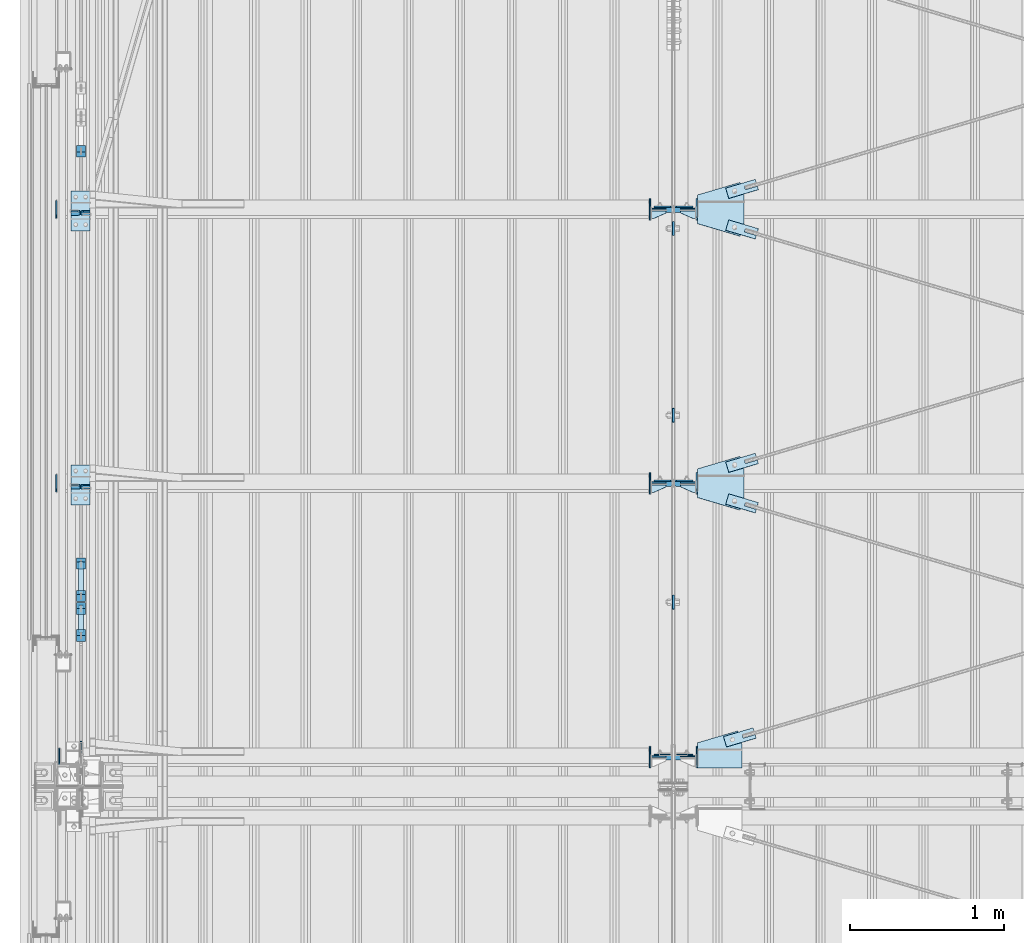
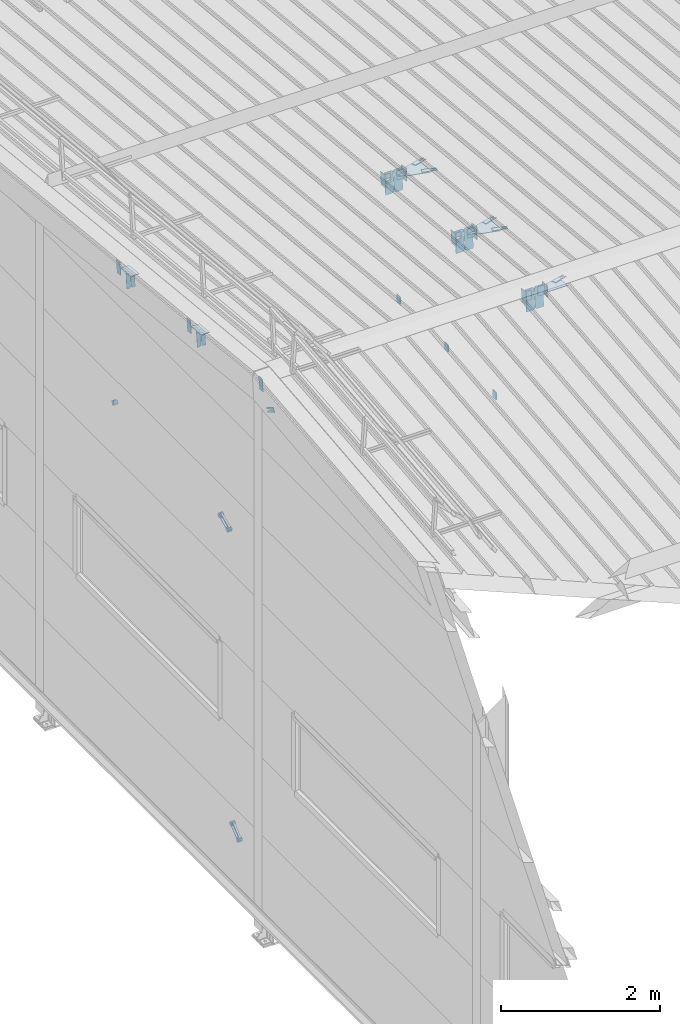
# One storey, part 118 of 709: 52 plates, 5 openings, 20 elements without a shape of their own.
"""IFC4 building model written with IfcOpenShell, lengths in millimetres."""

from ifc_helpers import new_model, si_unit, direction, frame, origin_with_axes, place, context, subcontext, project, spatial, line, indexed_curve, outline, extrude, material, element, aggregate, save


model = new_model("IFC4")

# Units and contexts
model_context = context("Model", 3, precision=0.2, world=origin_with_axes(), true_north=direction((0.0, 1.0)))
body_context = subcontext(model_context, "Body", "Model", "MODEL_VIEW")
ifc_project = project(units=[si_unit("LENGTHUNIT", "METRE", prefix="MILLI"), si_unit("AREAUNIT", "SQUARE_METRE"), si_unit("VOLUMEUNIT", "CUBIC_METRE"), si_unit("MASSUNIT", "GRAM", prefix="KILO"), si_unit("TIMEUNIT", "SECOND"), si_unit("PLANEANGLEUNIT", "RADIAN"), si_unit("SOLIDANGLEUNIT", "STERADIAN"), si_unit("THERMODYNAMICTEMPERATUREUNIT", "DEGREE_CELSIUS"), si_unit("LUMINOUSINTENSITYUNIT", "LUMEN")], contexts=[model_context])

# Site, building, storey
site_placement = place(None, origin_with_axes())
site = spatial("IfcSite", under=ifc_project, at=site_placement, CompositionType="ELEMENT")
building_placement = place(site_placement, origin_with_axes())
building = spatial("IfcBuilding", under=site, at=building_placement, Name="Undefined", CompositionType="ELEMENT")
storey_placement = place(building_placement, origin_with_axes())
storey = spatial("IfcBuildingStorey", under=building, at=storey_placement, Name="Undefined", CompositionType="ELEMENT", Elevation=0.0)

# Assembly, plates
assembly_1_placement = place(storey_placement, frame((4000.0, 21654.0, 7089.70002), z_axis=(-1.0, 0.0, 0.0), x_axis=(0.0, -0.9950371902, 0.099503719)))
assembly_1 = element("IfcElementAssembly", 1, at=assembly_1_placement, inside=storey)
ifc_material_1 = material(Name="C355-6", Category="STEEL")
plate_1_placement = place(assembly_1_placement, frame((10515.436, 163.0, 127.0), z_axis=(-1.0, 0.0, 0.0), x_axis=(0.0, 0.0, -1.0)))
plate_1 = element("IfcPlate", 2, at=plate_1_placement, material=ifc_material_1, ObjectType="585", context=body_context, shape_type="SolidModel", body=[
    extrude(outline(indexed_curve([(0.0, 0.0), (108.0, 0.0), (123.0, 15.0), (123.0, 311.0), (108.0, 326.0), (0.0, 326.0)], segments=[line(1, 2, 3, 4, 5, 6, 1)])), frame((0.0, 0.0, 4.0), z_axis=(0.0, 0.0, 1.0), x_axis=(1.0, 0.0, 0.0)), (0.0, 0.0, -1.0), 8.0),
])
plate_2_placement = place(assembly_1_placement, frame((10515.43997, 163.0, -127.0), z_axis=(1.0, 0.0, 0.0), x_axis=(0.0, 0.0, 1.0)))
plate_2 = element("IfcPlate", 3, at=plate_2_placement, material=ifc_material_1, ObjectType="589", context=body_context, shape_type="SolidModel", body=[
    extrude(outline(indexed_curve([(0.0, 0.0), (108.0, 0.0), (123.0, 15.0), (123.0, 311.0), (108.0, 326.0), (0.0, 326.0)], segments=[line(1, 2, 3, 4, 5, 6, 1)])), frame((0.0, 0.0, 4.0), z_axis=(0.0, 0.0, 1.0), x_axis=(1.0, 0.0, 0.0)), (0.0, 0.0, -1.0), 8.0),
])
plate_3_placement = place(assembly_1_placement, frame((8733.29131, 163.0, 127.0), z_axis=(-1.0, 0.0, 0.0), x_axis=(0.0, 0.0, -1.0)))
plate_3 = element("IfcPlate", 4, at=plate_3_placement, material=ifc_material_1, ObjectType="585", context=body_context, shape_type="SolidModel", body=[
    extrude(outline(indexed_curve([(0.0, 0.0), (108.0, 0.0), (123.0, 15.0), (123.0, 311.0), (108.0, 326.0), (0.0, 326.0)], segments=[line(1, 2, 3, 4, 5, 6, 1)])), frame((0.0, 0.0, 4.0), z_axis=(0.0, 0.0, 1.0), x_axis=(1.0, 0.0, 0.0)), (0.0, 0.0, -1.0), 8.0),
])
plate_4_placement = place(assembly_1_placement, frame((8733.29528, 163.0, -127.0), z_axis=(1.0, 0.0, 0.0), x_axis=(0.0, 0.0, 1.0)))
plate_4 = element("IfcPlate", 5, at=plate_4_placement, material=ifc_material_1, ObjectType="585", context=body_context, shape_type="SolidModel", body=[
    extrude(outline(indexed_curve([(0.0, 0.0), (108.0, 0.0), (123.0, 15.0), (123.0, 311.0), (108.0, 326.0), (0.0, 326.0)], segments=[line(1, 2, 3, 4, 5, 6, 1)])), frame((0.0, 0.0, 4.0), z_axis=(0.0, 0.0, 1.0), x_axis=(1.0, 0.0, 0.0)), (0.0, 0.0, -1.0), 8.0),
])
plate_5_placement = place(assembly_1_placement, frame((6951.14662, 163.0, 127.0), z_axis=(-1.0, 0.0, 0.0), x_axis=(0.0, 0.0, -1.0)))
plate_5 = element("IfcPlate", 6, at=plate_5_placement, material=ifc_material_1, ObjectType="585", context=body_context, shape_type="SolidModel", body=[
    extrude(outline(indexed_curve([(0.0, 0.0), (108.0, 0.0), (123.0, 15.0), (123.0, 311.0), (108.0, 326.0), (0.0, 326.0)], segments=[line(1, 2, 3, 4, 5, 6, 1)])), frame((0.0, 0.0, 4.0), z_axis=(0.0, 0.0, 1.0), x_axis=(1.0, 0.0, 0.0)), (0.0, 0.0, -1.0), 8.0),
])
plate_6_placement = place(assembly_1_placement, frame((6951.15059, 163.0, -127.0), z_axis=(1.0, 0.0, 0.0), x_axis=(0.0, 0.0, 1.0)))
plate_6 = element("IfcPlate", 7, at=plate_6_placement, material=ifc_material_1, ObjectType="585", context=body_context, shape_type="SolidModel", body=[
    extrude(outline(indexed_curve([(0.0, 0.0), (108.0, 0.0), (123.0, 15.0), (123.0, 311.0), (108.0, 326.0), (0.0, 326.0)], segments=[line(1, 2, 3, 4, 5, 6, 1)])), frame((0.0, 0.0, 4.0), z_axis=(0.0, 0.0, 1.0), x_axis=(1.0, 0.0, 0.0)), (0.0, 0.0, -1.0), 8.0),
])
aggregate(assembly_1, [plate_1, plate_2, plate_3, plate_4, plate_5, plate_6])

assembly_2_placement = place(storey_placement, frame((162.5, 16500.0, 7445.307), z_axis=(-1.0, 0.0, 0.0), x_axis=(0.0, -0.9950371902, 0.099503719)))
assembly_2 = element("IfcElementAssembly", 8, at=assembly_2_placement, inside=storey)
plate_7_placement = place(assembly_2_placement, frame((3577.48542, 115.0, 62.0), z_axis=(-1.0, 0.0, 0.0), x_axis=(0.0, 0.0, -1.0)))
plate_7 = element("IfcPlate", 9, at=plate_7_placement, material=ifc_material_1, ObjectType="594", context=body_context, shape_type="SolidModel", body=[
    extrude(outline(indexed_curve([(0.0, 0.0), (43.5, 0.0), (58.5, 15.0), (58.5, 215.0), (43.5, 230.0), (0.0, 230.0)], segments=[line(1, 2, 3, 4, 5, 6, 1)])), frame((0.0, 0.0, 4.0), z_axis=(0.0, 0.0, 1.0), x_axis=(1.0, 0.0, 0.0)), (0.0, 0.0, -1.0), 8.0),
])
plate_8_placement = place(assembly_2_placement, frame((3577.48542, -115.0, -62.0), z_axis=(-1.0, 0.0, 0.0), x_axis=(0.0, 0.0, 1.0)))
plate_8 = element("IfcPlate", 10, at=plate_8_placement, material=ifc_material_1, ObjectType="594", context=body_context, shape_type="SolidModel", body=[
    extrude(outline(indexed_curve([(0.0, 0.0), (43.5, 0.0), (58.5, 15.0), (58.5, 215.0), (43.5, 230.0), (0.0, 230.0)], segments=[line(1, 2, 3, 4, 5, 6, 1)])), frame((0.0, 0.0, 4.0), z_axis=(0.0, 0.0, 1.0), x_axis=(1.0, 0.0, 0.0)), (0.0, 0.0, -1.0), 8.0),
])
plate_9_placement = place(assembly_2_placement, frame((1795.34072, -115.0, -62.0), z_axis=(-1.0, 0.0, 0.0), x_axis=(0.0, 0.0, 1.0)))
plate_9 = element("IfcPlate", 11, at=plate_9_placement, material=ifc_material_1, ObjectType="594", context=body_context, shape_type="SolidModel", body=[
    extrude(outline(indexed_curve([(0.0, 0.0), (43.5, 0.0), (58.5, 15.0), (58.5, 215.0), (43.5, 230.0), (0.0, 230.0)], segments=[line(1, 2, 3, 4, 5, 6, 1)])), frame((0.0, 0.0, 4.0), z_axis=(0.0, 0.0, 1.0), x_axis=(1.0, 0.0, 0.0)), (0.0, 0.0, -1.0), 8.0),
])
plate_10_placement = place(assembly_2_placement, frame((1795.34072, 115.0, 62.0), z_axis=(-1.0, 0.0, 0.0), x_axis=(0.0, 0.0, -1.0)))
plate_10 = element("IfcPlate", 12, at=plate_10_placement, material=ifc_material_1, ObjectType="594", context=body_context, shape_type="SolidModel", body=[
    extrude(outline(indexed_curve([(0.0, 0.0), (43.5, 0.0), (58.5, 15.0), (58.5, 215.0), (43.5, 230.0), (0.0, 230.0)], segments=[line(1, 2, 3, 4, 5, 6, 1)])), frame((0.0, 0.0, 4.0), z_axis=(0.0, 0.0, 1.0), x_axis=(1.0, 0.0, 0.0)), (0.0, 0.0, -1.0), 8.0),
])
aggregate(assembly_2, [plate_7, plate_8, plate_9, plate_10])

# Assembly, plate
assembly_3_placement = place(storey_placement, frame((4000.0, 12149.25, 6100.00002), z_axis=(-1.0, 0.0, 0.0), x_axis=(0.0, 1.0, 0.0)))
assembly_3 = element("IfcElementAssembly", 13, at=assembly_3_placement, inside=storey)
plate_11_placement = place(assembly_3_placement, origin_with_axes())
plate_11 = element("IfcPlate", 14, at=plate_11_placement, material=ifc_material_1, ObjectType="491", context=body_context, shape_type="SolidModel", body=[
    extrude(outline(indexed_curve([(0.0, 0.0), (90.0, 0.0), (90.0, 110.0), (0.0, 110.0)], segments=[line(1, 2, 3, 4, 1)])), frame((0.0, 0.0, 6.0), z_axis=(0.0, 0.0, 1.0), x_axis=(1.0, 0.0, 0.0)), (0.0, 0.0, -1.0), 12.0),
])
aggregate(assembly_3, [plate_11])

assembly_4_placement = place(storey_placement, frame((4000.0, 13358.5, 6100.00002), z_axis=(-1.0, 0.0, 0.0), x_axis=(0.0, 1.0, 0.0)))
assembly_4 = element("IfcElementAssembly", 15, at=assembly_4_placement, inside=storey)
plate_12_placement = place(assembly_4_placement, origin_with_axes())
plate_12 = element("IfcPlate", 16, at=plate_12_placement, material=ifc_material_1, ObjectType="491", context=body_context, shape_type="SolidModel", body=[
    extrude(outline(indexed_curve([(0.0, 0.0), (90.0, 0.0), (90.0, 110.0), (0.0, 110.0)], segments=[line(1, 2, 3, 4, 1)])), frame((0.0, 0.0, 6.0), z_axis=(0.0, 0.0, 1.0), x_axis=(1.0, 0.0, 0.0)), (0.0, 0.0, -1.0), 12.0),
])
aggregate(assembly_4, [plate_12])

assembly_5_placement = place(storey_placement, frame((4000.0, 14567.75, 6100.00002), z_axis=(-1.0, 0.0, 0.0), x_axis=(0.0, 1.0, 0.0)))
assembly_5 = element("IfcElementAssembly", 17, at=assembly_5_placement, inside=storey)
plate_13_placement = place(assembly_5_placement, origin_with_axes())
plate_13 = element("IfcPlate", 18, at=plate_13_placement, material=ifc_material_1, ObjectType="491", context=body_context, shape_type="SolidModel", body=[
    extrude(outline(indexed_curve([(0.0, 0.0), (90.0, 0.0), (90.0, 110.0), (0.0, 110.0)], segments=[line(1, 2, 3, 4, 1)])), frame((0.0, 0.0, 6.0), z_axis=(0.0, 0.0, 1.0), x_axis=(1.0, 0.0, 0.0)), (0.0, 0.0, -1.0), 12.0),
])
aggregate(assembly_5, [plate_13])

# Assembly, plates
assembly_6_placement = place(storey_placement, frame((135.0, 11957.52993, 702.47387), z_axis=(0.0, 0.7603239329, 0.649544084), x_axis=(1.0, 0.0, 0.0)))
assembly_6 = element("IfcElementAssembly", 19, at=assembly_6_placement, inside=storey)
ifc_material_2 = material(Name="Steel_Undefined", Category="STEEL")
plate_14_placement = place(assembly_6_placement, origin_with_axes())
plate_14 = element("IfcPlate", 20, at=plate_14_placement, material=ifc_material_2, ObjectType="482", context=body_context, shape_type="SolidModel", body=[
    extrude(outline(indexed_curve([(0.0, 0.0), (60.0, 0.0), (60.0, 60.0), (0.0, 60.0)], segments=[line(1, 2, 3, 4, 1)])), frame((0.0, 0.0, 25.0), z_axis=(0.0, 0.0, 1.0), x_axis=(1.0, 0.0, 0.0)), (0.0, 0.0, -1.0), 50.0),
])
plate_15_placement = place(assembly_6_placement, frame((15.0, 66.0, 230.0), z_axis=(0.0, 1.0, 0.0), x_axis=(1.0, 0.0, 0.0)))
plate_15 = element("IfcPlate", 21, at=plate_15_placement, material=ifc_material_2, ObjectType="484", context=body_context, shape_type="SolidModel", body=[
    extrude(outline(indexed_curve([(0.0, 0.0), (30.0, 0.0), (30.0, 230.0), (0.0, 230.0)], segments=[line(1, 2, 3, 4, 1)])), frame((0.0, 0.0, 6.0), z_axis=(0.0, 0.0, 1.0), x_axis=(1.0, 0.0, 0.0)), (0.0, 0.0, -1.0), 12.0),
])
plate_16_placement = place(assembly_6_placement, frame((15.0, -6.0, 230.0), z_axis=(0.0, 1.0, 0.0), x_axis=(1.0, 0.0, 0.0)))
plate_16 = element("IfcPlate", 22, at=plate_16_placement, material=ifc_material_2, ObjectType="484", context=body_context, shape_type="SolidModel", body=[
    extrude(outline(indexed_curve([(0.0, 0.0), (30.0, 0.0), (30.0, 230.0), (0.0, 230.0)], segments=[line(1, 2, 3, 4, 1)])), frame((0.0, 0.0, 6.0), z_axis=(0.0, 0.0, 1.0), x_axis=(1.0, 0.0, 0.0)), (0.0, 0.0, -1.0), 12.0),
])
plate_17_placement = place(assembly_6_placement, frame((0.0, 0.0, 230.0), z_axis=(0.0, 0.0, 1.0), x_axis=(1.0, 0.0, 0.0)))
plate_17 = element("IfcPlate", 23, at=plate_17_placement, material=ifc_material_2, ObjectType="483", context=body_context, shape_type="SolidModel", body=[
    extrude(outline(indexed_curve([(0.0, 0.0), (60.0, 0.0), (60.0, 60.0), (0.0, 60.0)], segments=[line(1, 2, 3, 4, 1)])), frame((0.0, 0.0, 25.0), z_axis=(0.0, 0.0, 1.0), x_axis=(1.0, 0.0, 0.0)), (0.0, 0.0, -1.0), 50.0),
])
aggregate(assembly_6, [plate_14, plate_15, plate_16, plate_17])

# Assembly, plate
assembly_7_placement = place(storey_placement, frame((165.0, 15212.89749, 5439.71077), z_axis=(-1.0, 0.0, 0.0), x_axis=(0.0, -0.866144648, 0.499793406)))
assembly_7 = element("IfcElementAssembly", 24, at=assembly_7_placement, inside=storey)
plate_18_placement = place(assembly_7_placement, frame((4543.87607, -11.0, 0.0), z_axis=(0.0, 0.0, -1.0), x_axis=(1.0, 0.0, 0.0)))
plate_18 = element("IfcPlate", 25, at=plate_18_placement, material=ifc_material_1, ObjectType="490", context=body_context, shape_type="SolidModel", body=[
    extrude(outline(indexed_curve([(0.0, 0.0), (80.0, 0.0), (80.0, -22.0), (0.0, -22.0), (0.0, -46.0), (200.0, -46.0), (200.0, 24.0), (0.0, 24.0)], segments=[line(1, 2, 3, 4, 5, 6, 7, 8, 1)])), frame((0.0, 0.0, 4.0), z_axis=(0.0, 0.0, 1.0), x_axis=(1.0, 0.0, 0.0)), (0.0, 0.0, -1.0), 8.0),
])
aggregate(assembly_7, [plate_18])

assembly_8_placement = place(storey_placement, frame((135.0, 15128.28466, 5523.17135), z_axis=(0.0, 0.866144648, -0.499793406), x_axis=(1.0, 0.0, 0.0)))
assembly_8 = element("IfcElementAssembly", 26, at=assembly_8_placement, inside=storey)
plate_19_placement = place(assembly_8_placement, origin_with_axes())
plate_19 = element("IfcPlate", 27, at=plate_19_placement, material=ifc_material_2, ObjectType="482", context=body_context, shape_type="SolidModel", body=[
    extrude(outline(indexed_curve([(0.0, 0.0), (60.0, 0.0), (60.0, 60.0), (0.0, 60.0)], segments=[line(1, 2, 3, 4, 1)])), frame((0.0, 0.0, 25.0), z_axis=(0.0, 0.0, 1.0), x_axis=(1.0, 0.0, 0.0)), (0.0, 0.0, -1.0), 50.0),
])
aggregate(assembly_8, [plate_19])

# Assembly, plates
assembly_9_placement = place(storey_placement, frame((135.0, 12222.02873, 5319.05338), z_axis=(0.0, 0.9030466941, 0.429542394), x_axis=(1.0, 0.0, 0.0)))
assembly_9 = element("IfcElementAssembly", 28, at=assembly_9_placement, inside=storey)
plate_20_placement = place(assembly_9_placement, frame((15.0, 66.0, 230.0), z_axis=(0.0, 1.0, 0.0), x_axis=(1.0, 0.0, 0.0)))
plate_20 = element("IfcPlate", 29, at=plate_20_placement, material=ifc_material_2, ObjectType="484", context=body_context, shape_type="SolidModel", body=[
    extrude(outline(indexed_curve([(0.0, 0.0), (30.0, 0.0), (30.0, 230.0), (0.0, 230.0)], segments=[line(1, 2, 3, 4, 1)])), frame((0.0, 0.0, 6.0), z_axis=(0.0, 0.0, 1.0), x_axis=(1.0, 0.0, 0.0)), (0.0, 0.0, -1.0), 12.0),
])
plate_21_placement = place(assembly_9_placement, frame((15.0, -6.0, 230.0), z_axis=(0.0, 1.0, 0.0), x_axis=(1.0, 0.0, 0.0)))
plate_21 = element("IfcPlate", 30, at=plate_21_placement, material=ifc_material_2, ObjectType="484", context=body_context, shape_type="SolidModel", body=[
    extrude(outline(indexed_curve([(0.0, 0.0), (30.0, 0.0), (30.0, 230.0), (0.0, 230.0)], segments=[line(1, 2, 3, 4, 1)])), frame((0.0, 0.0, 6.0), z_axis=(0.0, 0.0, 1.0), x_axis=(1.0, 0.0, 0.0)), (0.0, 0.0, -1.0), 12.0),
])
plate_22_placement = place(assembly_9_placement, frame((0.0, 0.0, 230.0), z_axis=(0.0, 0.0, 1.0), x_axis=(1.0, 0.0, 0.0)))
plate_22 = element("IfcPlate", 31, at=plate_22_placement, material=ifc_material_2, ObjectType="483", context=body_context, shape_type="SolidModel", body=[
    extrude(outline(indexed_curve([(0.0, 0.0), (60.0, 0.0), (60.0, 60.0), (0.0, 60.0)], segments=[line(1, 2, 3, 4, 1)])), frame((0.0, 0.0, 25.0), z_axis=(0.0, 0.0, 1.0), x_axis=(1.0, 0.0, 0.0)), (0.0, 0.0, -1.0), 50.0),
])
plate_23_placement = place(assembly_9_placement, origin_with_axes())
plate_23 = element("IfcPlate", 32, at=plate_23_placement, material=ifc_material_2, ObjectType="482", context=body_context, shape_type="SolidModel", body=[
    extrude(outline(indexed_curve([(0.0, 0.0), (60.0, 0.0), (60.0, 60.0), (0.0, 60.0)], segments=[line(1, 2, 3, 4, 1)])), frame((0.0, 0.0, 25.0), z_axis=(0.0, 0.0, 1.0), x_axis=(1.0, 0.0, 0.0)), (0.0, 0.0, -1.0), 50.0),
])
aggregate(assembly_9, [plate_20, plate_21, plate_22, plate_23])

# Assembly, plate, voiding feature
assembly_10_placement = place(storey_placement, frame((4000.0, 11190.84566, 8217.41945), z_axis=(0.2847296511, -0.9538504697, 0.095385047), x_axis=(0.9586078582, 0.2833165921, -0.028331659)))
assembly_10 = element("IfcElementAssembly", 33, at=assembly_10_placement, inside=storey)
plate_24_placement = place(assembly_10_placement, frame((348.68279, 0.0, -35.0), z_axis=(0.0, 1.0, 0.0), x_axis=(0.0, 0.0, 1.0)))
plate_24 = element("IfcPlate", 34, at=plate_24_placement, material=ifc_material_1, ObjectType="574", context=body_context, shape_type="SolidModel", body=[
    extrude(outline(indexed_curve([(0.0, 0.0), (70.0, 0.0), (70.0, 200.0), (0.0, 200.0)], segments=[line(1, 2, 3, 4, 1)])), frame((0.0, 0.0, 4.0), z_axis=(0.0, 0.0, 1.0), x_axis=(1.0, 0.0, 0.0)), (0.0, 0.0, -1.0), 8.0),
])
voiding_feature_1_placement = place(plate_24_placement, frame((24.0, 120.0, 0.0), z_axis=(0.0, 0.0, 1.0), x_axis=(1.0, 0.0, 0.0)))
element("IfcVoidingFeature", 35, at=voiding_feature_1_placement, cuts=plate_24, Name="PLATE", PredefinedType="HOLE", context=body_context, shape_type="SolidModel", body=[
    extrude(outline(indexed_curve([(0.0, 0.0), (22.0, 0.0), (22.0, 85.0), (0.0, 85.0)], segments=[line(1, 2, 3, 4, 1)])), frame((0.0, 0.0, 6.5), z_axis=(0.0, 0.0, 1.0), x_axis=(1.0, 0.0, 0.0)), (0.0, 0.0, -1.0), 13.0),
])
aggregate(assembly_10, [plate_24])

assembly_11_placement = place(storey_placement, frame((4000.0, 12964.14591, 8040.08943), z_axis=(-0.2847296511, -0.9538504697, 0.095385047), x_axis=(0.9586078582, -0.2833165921, 0.028331659)))
assembly_11 = element("IfcElementAssembly", 36, at=assembly_11_placement, inside=storey)
plate_25_placement = place(assembly_11_placement, frame((363.68279, 0.0, -35.0), z_axis=(0.0, 1.0, 0.0), x_axis=(0.0, 0.0, 1.0)))
plate_25 = element("IfcPlate", 37, at=plate_25_placement, material=ifc_material_1, ObjectType="574", context=body_context, shape_type="SolidModel", body=[
    extrude(outline(indexed_curve([(0.0, 0.0), (70.0, 0.0), (70.0, 200.0), (0.0, 200.0)], segments=[line(1, 2, 3, 4, 1)])), frame((0.0, 0.0, 4.0), z_axis=(0.0, 0.0, 1.0), x_axis=(1.0, 0.0, 0.0)), (0.0, 0.0, -1.0), 8.0),
])
voiding_feature_2_placement = place(plate_25_placement, frame((24.0, 120.0, 0.0), z_axis=(0.0, 0.0, 1.0), x_axis=(1.0, 0.0, 0.0)))
element("IfcVoidingFeature", 38, at=voiding_feature_2_placement, cuts=plate_25, Name="PLATE", PredefinedType="HOLE", context=body_context, shape_type="SolidModel", body=[
    extrude(outline(indexed_curve([(0.0, 0.0), (22.0, 0.0), (22.0, 85.0), (0.0, 85.0)], segments=[line(1, 2, 3, 4, 1)])), frame((0.0, 0.0, 6.5), z_axis=(0.0, 0.0, 1.0), x_axis=(1.0, 0.0, 0.0)), (0.0, 0.0, -1.0), 13.0),
])
aggregate(assembly_11, [plate_25])

assembly_12_placement = place(storey_placement, frame((4000.0, 12964.14591, 8040.08943), z_axis=(0.2847296511, -0.9538504697, 0.095385047), x_axis=(0.9586078582, 0.2833165921, -0.028331659)))
assembly_12 = element("IfcElementAssembly", 39, at=assembly_12_placement, inside=storey)
plate_26_placement = place(assembly_12_placement, frame((363.68279, 0.0, -35.0), z_axis=(0.0, 1.0, 0.0), x_axis=(0.0, 0.0, 1.0)))
plate_26 = element("IfcPlate", 40, at=plate_26_placement, material=ifc_material_1, ObjectType="574", context=body_context, shape_type="SolidModel", body=[
    extrude(outline(indexed_curve([(0.0, 0.0), (70.0, 0.0), (70.0, 200.0), (0.0, 200.0)], segments=[line(1, 2, 3, 4, 1)])), frame((0.0, 0.0, 4.0), z_axis=(0.0, 0.0, 1.0), x_axis=(1.0, 0.0, 0.0)), (0.0, 0.0, -1.0), 8.0),
])
voiding_feature_3_placement = place(plate_26_placement, frame((24.0, 120.0, 0.0), z_axis=(0.0, 0.0, 1.0), x_axis=(1.0, 0.0, 0.0)))
element("IfcVoidingFeature", 41, at=voiding_feature_3_placement, cuts=plate_26, Name="PLATE", PredefinedType="HOLE", context=body_context, shape_type="SolidModel", body=[
    extrude(outline(indexed_curve([(0.0, 0.0), (22.0, 0.0), (22.0, 85.0), (0.0, 85.0)], segments=[line(1, 2, 3, 4, 1)])), frame((0.0, 0.0, 6.5), z_axis=(0.0, 0.0, 1.0), x_axis=(1.0, 0.0, 0.0)), (0.0, 0.0, -1.0), 13.0),
])
aggregate(assembly_12, [plate_26])

assembly_13_placement = place(storey_placement, frame((4000.0, 14737.44615, 7862.7594), z_axis=(-0.2847296511, -0.9538504697, 0.095385047), x_axis=(0.9586078582, -0.2833165921, 0.028331659)))
assembly_13 = element("IfcElementAssembly", 42, at=assembly_13_placement, inside=storey)
plate_27_placement = place(assembly_13_placement, frame((363.68279, 0.0, -35.0), z_axis=(0.0, 1.0, 0.0), x_axis=(0.0, 0.0, 1.0)))
plate_27 = element("IfcPlate", 43, at=plate_27_placement, material=ifc_material_1, ObjectType="574", context=body_context, shape_type="SolidModel", body=[
    extrude(outline(indexed_curve([(0.0, 0.0), (70.0, 0.0), (70.0, 200.0), (0.0, 200.0)], segments=[line(1, 2, 3, 4, 1)])), frame((0.0, 0.0, 4.0), z_axis=(0.0, 0.0, 1.0), x_axis=(1.0, 0.0, 0.0)), (0.0, 0.0, -1.0), 8.0),
])
voiding_feature_4_placement = place(plate_27_placement, frame((24.0, 120.0, 0.0), z_axis=(0.0, 0.0, 1.0), x_axis=(1.0, 0.0, 0.0)))
element("IfcVoidingFeature", 44, at=voiding_feature_4_placement, cuts=plate_27, Name="PLATE", PredefinedType="HOLE", context=body_context, shape_type="SolidModel", body=[
    extrude(outline(indexed_curve([(0.0, 0.0), (22.0, 0.0), (22.0, 85.0), (0.0, 85.0)], segments=[line(1, 2, 3, 4, 1)])), frame((0.0, 0.0, 6.5), z_axis=(0.0, 0.0, 1.0), x_axis=(1.0, 0.0, 0.0)), (0.0, 0.0, -1.0), 13.0),
])
aggregate(assembly_13, [plate_27])

assembly_14_placement = place(storey_placement, frame((4000.0, 14737.44615, 7862.7594), z_axis=(0.2847296511, -0.9538504697, 0.095385047), x_axis=(0.9586078582, 0.2833165921, -0.028331659)))
assembly_14 = element("IfcElementAssembly", 45, at=assembly_14_placement, inside=storey)
plate_28_placement = place(assembly_14_placement, frame((363.68279, 0.0, -35.0), z_axis=(0.0, 1.0, 0.0), x_axis=(0.0, 0.0, 1.0)))
plate_28 = element("IfcPlate", 46, at=plate_28_placement, material=ifc_material_1, ObjectType="574", context=body_context, shape_type="SolidModel", body=[
    extrude(outline(indexed_curve([(0.0, 0.0), (70.0, 0.0), (70.0, 200.0), (0.0, 200.0)], segments=[line(1, 2, 3, 4, 1)])), frame((0.0, 0.0, 4.0), z_axis=(0.0, 0.0, 1.0), x_axis=(1.0, 0.0, 0.0)), (0.0, 0.0, -1.0), 8.0),
])
voiding_feature_5_placement = place(plate_28_placement, frame((24.0, 120.0, 0.0), z_axis=(0.0, 0.0, 1.0), x_axis=(1.0, 0.0, 0.0)))
element("IfcVoidingFeature", 47, at=voiding_feature_5_placement, cuts=plate_28, Name="PLATE", PredefinedType="HOLE", context=body_context, shape_type="SolidModel", body=[
    extrude(outline(indexed_curve([(0.0, 0.0), (22.0, 0.0), (22.0, 85.0), (0.0, 85.0)], segments=[line(1, 2, 3, 4, 1)])), frame((0.0, 0.0, 6.5), z_axis=(0.0, 0.0, 1.0), x_axis=(1.0, 0.0, 0.0)), (0.0, 0.0, -1.0), 13.0),
])
aggregate(assembly_14, [plate_28])

# Assembly, plates
assembly_15_placement = place(storey_placement, frame((4000.0, 11190.04963, 8209.41925), z_axis=(0.0, -0.9950371902, 0.099503719), x_axis=(-1.0, 0.0, 0.0)))
assembly_15 = element("IfcElementAssembly", 48, at=assembly_15_placement, inside=storey)
plate_29_placement = place(assembly_15_placement, frame((151.0, -98.0, -60.0), z_axis=(-1.0, 0.0, 0.0), x_axis=(0.0, 0.0, 1.0)))
plate_29 = element("IfcPlate", 49, at=plate_29_placement, material=ifc_material_1, ObjectType="586", context=body_context, shape_type="SolidModel", body=[
    extrude(outline(indexed_curve([(0.0, 0.0), (120.0, 0.0), (120.0, 196.0), (0.0, 196.0)], segments=[line(1, 2, 3, 4, 1)])), frame((0.0, 0.0, 4.0), z_axis=(0.0, 0.0, 1.0), x_axis=(1.0, 0.0, 0.0)), (0.0, 0.0, -1.0), 8.0),
])
plate_30_placement = place(assembly_15_placement, frame((47.0, -65.0, 0.0), z_axis=(0.0, 0.0, 1.0), x_axis=(1.0, 0.0, 0.0)))
plate_30 = element("IfcPlate", 50, at=plate_30_placement, material=ifc_material_1, ObjectType="587", context=body_context, shape_type="SolidModel", body=[
    extrude(outline(indexed_curve([(0.0, 0.0), (100.0, 0.0), (100.0, 130.0), (0.0, 130.0)], segments=[line(1, 2, 3, 4, 1)])), frame((0.0, 0.0, 4.0), z_axis=(0.0, 0.0, 1.0), x_axis=(1.0, 0.0, 0.0)), (0.0, 0.0, -1.0), 8.0),
])
plate_31_placement = place(assembly_15_placement, frame((3976.0, -97.0, 47.0), z_axis=(1.0, 0.0, 0.0), x_axis=(0.0, 0.0, -1.0)))
plate_31 = element("IfcPlate", 51, at=plate_31_placement, material=ifc_material_1, ObjectType="592", context=body_context, shape_type="SolidModel", body=[
    extrude(outline(indexed_curve([(0.0, 0.0), (94.0, 0.0), (94.0, 194.0), (0.0, 194.0)], segments=[line(1, 2, 3, 4, 1)])), frame((0.0, 0.0, 4.0), z_axis=(0.0, 0.0, 1.0), x_axis=(1.0, 0.0, 0.0)), (0.0, 0.0, -1.0), 8.0),
])
aggregate(assembly_15, [plate_29, plate_30, plate_31])

assembly_16_placement = place(storey_placement, frame((4000.0, 12963.34988, 8032.08923), z_axis=(0.0, -0.9950371902, 0.099503719), x_axis=(-1.0, 0.0, 0.0)))
assembly_16 = element("IfcElementAssembly", 52, at=assembly_16_placement, inside=storey)
plate_32_placement = place(assembly_16_placement, frame((3775.5, 104.0, -130.0), z_axis=(0.0, 1.0, 0.0), x_axis=(0.0, 0.0, 1.0)))
plate_32 = element("IfcPlate", 53, at=plate_32_placement, material=ifc_material_1, ObjectType="593", context=body_context, shape_type="SolidModel", body=[
    extrude(outline(indexed_curve([(0.0, 0.0), (260.0, 0.0), (260.0, 124.0), (0.0, 124.0)], segments=[line(1, 2, 3, 4, 1)])), frame((0.0, 0.0, 4.0), z_axis=(0.0, 0.0, 1.0), x_axis=(1.0, 0.0, 0.0)), (0.0, 0.0, -1.0), 8.0),
])
plate_33_placement = place(assembly_16_placement, frame((47.0, 0.0, 60.0), z_axis=(0.0, 1.0, 0.0), x_axis=(1.0, 0.0, 0.0)))
plate_33 = element("IfcPlate", 54, at=plate_33_placement, material=ifc_material_1, ObjectType="588", context=body_context, shape_type="SolidModel", body=[
    extrude(outline(indexed_curve([(0.0, 36.0), (80.0, 0.0), (100.0, 0.0), (100.0, 56.0), (0.0, 56.0)], segments=[line(1, 2, 3, 4, 5, 1)])), frame((0.0, 0.0, 4.0), z_axis=(0.0, 0.0, 1.0), x_axis=(1.0, 0.0, 0.0)), (0.0, 0.0, -1.0), 8.0),
])
plate_34_placement = place(assembly_16_placement, frame((47.0, -65.0, 0.0), z_axis=(0.0, 0.0, 1.0), x_axis=(1.0, 0.0, 0.0)))
plate_34 = element("IfcPlate", 55, at=plate_34_placement, material=ifc_material_1, ObjectType="587", context=body_context, shape_type="SolidModel", body=[
    extrude(outline(indexed_curve([(0.0, 0.0), (100.0, 0.0), (100.0, 130.0), (0.0, 130.0)], segments=[line(1, 2, 3, 4, 1)])), frame((0.0, 0.0, 4.0), z_axis=(0.0, 0.0, 1.0), x_axis=(1.0, 0.0, 0.0)), (0.0, 0.0, -1.0), 8.0),
])
plate_35_placement = place(assembly_16_placement, frame((151.0, -98.0, -60.0), z_axis=(-1.0, 0.0, 0.0), x_axis=(0.0, 0.0, 1.0)))
plate_35 = element("IfcPlate", 56, at=plate_35_placement, material=ifc_material_1, ObjectType="586", context=body_context, shape_type="SolidModel", body=[
    extrude(outline(indexed_curve([(0.0, 0.0), (120.0, 0.0), (120.0, 196.0), (0.0, 196.0)], segments=[line(1, 2, 3, 4, 1)])), frame((0.0, 0.0, 4.0), z_axis=(0.0, 0.0, 1.0), x_axis=(1.0, 0.0, 0.0)), (0.0, 0.0, -1.0), 8.0),
])
plate_36_placement = place(assembly_16_placement, frame((3996.0, -97.0, 47.0), z_axis=(1.0, 0.0, 0.0), x_axis=(0.0, 0.0, -1.0)))
plate_36 = element("IfcPlate", 57, at=plate_36_placement, material=ifc_material_1, ObjectType="592", context=body_context, shape_type="SolidModel", body=[
    extrude(outline(indexed_curve([(0.0, 0.0), (94.0, 0.0), (94.0, 194.0), (0.0, 194.0)], segments=[line(1, 2, 3, 4, 1)])), frame((0.0, 0.0, 4.0), z_axis=(0.0, 0.0, 1.0), x_axis=(1.0, 0.0, 0.0)), (0.0, 0.0, -1.0), 8.0),
])
aggregate(assembly_16, [plate_32, plate_33, plate_34, plate_35, plate_36])

assembly_17_placement = place(storey_placement, frame((4000.0, 14736.65012, 7854.7592), z_axis=(0.0, -0.9950371902, 0.099503719), x_axis=(-1.0, 0.0, 0.0)))
assembly_17 = element("IfcElementAssembly", 58, at=assembly_17_placement, inside=storey)
plate_37_placement = place(assembly_17_placement, frame((3996.0, -97.0, 47.0), z_axis=(1.0, 0.0, 0.0), x_axis=(0.0, 0.0, -1.0)))
plate_37 = element("IfcPlate", 59, at=plate_37_placement, material=ifc_material_1, ObjectType="592", context=body_context, shape_type="SolidModel", body=[
    extrude(outline(indexed_curve([(0.0, 0.0), (94.0, 0.0), (94.0, 194.0), (0.0, 194.0)], segments=[line(1, 2, 3, 4, 1)])), frame((0.0, 0.0, 4.0), z_axis=(0.0, 0.0, 1.0), x_axis=(1.0, 0.0, 0.0)), (0.0, 0.0, -1.0), 8.0),
])
plate_38_placement = place(assembly_17_placement, frame((3775.5, 104.0, -130.0), z_axis=(0.0, 1.0, 0.0), x_axis=(0.0, 0.0, 1.0)))
plate_38 = element("IfcPlate", 60, at=plate_38_placement, material=ifc_material_1, ObjectType="593", context=body_context, shape_type="SolidModel", body=[
    extrude(outline(indexed_curve([(0.0, 0.0), (260.0, 0.0), (260.0, 124.0), (0.0, 124.0)], segments=[line(1, 2, 3, 4, 1)])), frame((0.0, 0.0, 4.0), z_axis=(0.0, 0.0, 1.0), x_axis=(1.0, 0.0, 0.0)), (0.0, 0.0, -1.0), 8.0),
])
plate_39_placement = place(assembly_17_placement, frame((47.0, 0.0, 60.0), z_axis=(0.0, 1.0, 0.0), x_axis=(1.0, 0.0, 0.0)))
plate_39 = element("IfcPlate", 61, at=plate_39_placement, material=ifc_material_1, ObjectType="588", context=body_context, shape_type="SolidModel", body=[
    extrude(outline(indexed_curve([(0.0, 36.0), (80.0, 0.0), (100.0, 0.0), (100.0, 56.0), (0.0, 56.0)], segments=[line(1, 2, 3, 4, 5, 1)])), frame((0.0, 0.0, 4.0), z_axis=(0.0, 0.0, 1.0), x_axis=(1.0, 0.0, 0.0)), (0.0, 0.0, -1.0), 8.0),
])
plate_40_placement = place(assembly_17_placement, frame((47.0, -65.0, 0.0), z_axis=(0.0, 0.0, 1.0), x_axis=(1.0, 0.0, 0.0)))
plate_40 = element("IfcPlate", 62, at=plate_40_placement, material=ifc_material_1, ObjectType="587", context=body_context, shape_type="SolidModel", body=[
    extrude(outline(indexed_curve([(0.0, 0.0), (100.0, 0.0), (100.0, 130.0), (0.0, 130.0)], segments=[line(1, 2, 3, 4, 1)])), frame((0.0, 0.0, 4.0), z_axis=(0.0, 0.0, 1.0), x_axis=(1.0, 0.0, 0.0)), (0.0, 0.0, -1.0), 8.0),
])
plate_41_placement = place(assembly_17_placement, frame((151.0, -98.0, -60.0), z_axis=(-1.0, 0.0, 0.0), x_axis=(0.0, 0.0, 1.0)))
plate_41 = element("IfcPlate", 63, at=plate_41_placement, material=ifc_material_1, ObjectType="586", context=body_context, shape_type="SolidModel", body=[
    extrude(outline(indexed_curve([(0.0, 0.0), (120.0, 0.0), (120.0, 196.0), (0.0, 196.0)], segments=[line(1, 2, 3, 4, 1)])), frame((0.0, 0.0, 4.0), z_axis=(0.0, 0.0, 1.0), x_axis=(1.0, 0.0, 0.0)), (0.0, 0.0, -1.0), 8.0),
])
aggregate(assembly_17, [plate_37, plate_38, plate_39, plate_40, plate_41])

assembly_18_placement = place(storey_placement, frame((10000.0, 11191.04467, 8219.40952), z_axis=(0.0, -0.9950371902, 0.099503719), x_axis=(-1.0, 0.0, 0.0)))
assembly_18 = element("IfcElementAssembly", 64, at=assembly_18_placement, inside=storey)
plate_42_placement = place(assembly_18_placement, frame((5849.0, -88.0, 60.0), z_axis=(1.0, 0.0, 0.0), x_axis=(0.0, 0.0, -1.0)))
plate_42 = element("IfcPlate", 65, at=plate_42_placement, material=ifc_material_1, ObjectType="590", context=body_context, shape_type="SolidModel", body=[
    extrude(outline(indexed_curve([(0.0, 0.0), (120.0, 0.0), (120.0, 176.0), (0.0, 176.0)], segments=[line(1, 2, 3, 4, 1)])), frame((0.0, 0.0, 4.0), z_axis=(0.0, 0.0, 1.0), x_axis=(1.0, 0.0, 0.0)), (0.0, 0.0, -1.0), 8.0),
])
plate_43_placement = place(assembly_18_placement, frame((5845.0, 10.0, 70.0), z_axis=(0.0, -1.0, 0.0), x_axis=(-1.0, 0.0, 0.0)))
plate_43 = element("IfcPlate", 66, at=plate_43_placement, material=ifc_material_1, Name="PLATE", ObjectType="577", context=body_context, shape_type="SolidModel", body=[
    extrude(outline(indexed_curve([(0.0, 0.0), (287.92369, 0.0), (287.92369, 154.61594), (262.29802, 240.89065), (0.0, 162.98181)], segments=[line(1, 2, 3, 4, 5, 1)])), frame((0.0, 0.0, 4.0), z_axis=(0.0, 0.0, 1.0), x_axis=(1.0, 0.0, 0.0)), (0.0, 0.0, -1.0), 8.0),
])
plate_44_placement = place(assembly_18_placement, frame((5953.0, 65.0, 0.0), z_axis=(0.0, 0.0, 1.0), x_axis=(-1.0, 0.0, 0.0)))
plate_44 = element("IfcPlate", 67, at=plate_44_placement, material=ifc_material_1, ObjectType="587", context=body_context, shape_type="SolidModel", body=[
    extrude(outline(indexed_curve([(0.0, 0.0), (100.0, 0.0), (100.0, 130.0), (0.0, 130.0)], segments=[line(1, 2, 3, 4, 1)])), frame((0.0, 0.0, 4.0), z_axis=(0.0, 0.0, 1.0), x_axis=(1.0, 0.0, 0.0)), (0.0, 0.0, -1.0), 8.0),
])
aggregate(assembly_18, [plate_42, plate_43, plate_44])

assembly_19_placement = place(storey_placement, frame((10000.0, 12963.34988, 8032.12913), z_axis=(0.0, -0.9950371902, 0.099503719), x_axis=(-1.0, 0.0, 0.0)))
assembly_19 = element("IfcElementAssembly", 68, at=assembly_19_placement, inside=storey)
plate_45_placement = place(assembly_19_placement, frame((5849.0, -98.0, 60.0), z_axis=(1.0, 0.0, 0.0), x_axis=(0.0, 0.0, -1.0)))
plate_45 = element("IfcPlate", 69, at=plate_45_placement, material=ifc_material_1, ObjectType="586", context=body_context, shape_type="SolidModel", body=[
    extrude(outline(indexed_curve([(0.0, 0.0), (120.0, 0.0), (120.0, 196.0), (0.0, 196.0)], segments=[line(1, 2, 3, 4, 1)])), frame((0.0, 0.0, 4.0), z_axis=(0.0, 0.0, 1.0), x_axis=(1.0, 0.0, 0.0)), (0.0, 0.0, -1.0), 8.0),
])
plate_46_placement = place(assembly_19_placement, frame((5953.0, 0.0, 60.0), z_axis=(0.0, -1.0, 0.0), x_axis=(-1.0, 0.0, 0.0)))
plate_46 = element("IfcPlate", 70, at=plate_46_placement, material=ifc_material_1, ObjectType="588", context=body_context, shape_type="SolidModel", body=[
    extrude(outline(indexed_curve([(0.0, 36.0), (80.0, 0.0), (100.0, 0.0), (100.0, 56.0), (0.0, 56.0)], segments=[line(1, 2, 3, 4, 5, 1)])), frame((0.0, 0.0, 4.0), z_axis=(0.0, 0.0, 1.0), x_axis=(1.0, 0.0, 0.0)), (0.0, 0.0, -1.0), 8.0),
])
plate_47_placement = place(assembly_19_placement, frame((5845.00055, 0.0, -92.98165), z_axis=(0.0, -1.0, 0.0), x_axis=(0.0, 0.0, 1.0)))
plate_47 = element("IfcPlate", 71, at=plate_47_placement, material=ifc_material_1, ObjectType="576", context=body_context, shape_type="SolidModel", body=[
    extrude(outline(indexed_curve([(0.0, 0.0), (185.9633, 0.0), (268.14324, 276.67769), (181.86854, 302.30336), (4.09476, 302.30336), (-82.17995, 276.67769)], segments=[line(1, 2, 3, 4, 5, 6, 1)])), frame((0.0, 0.0, 4.0), z_axis=(0.0, 0.0, 1.0), x_axis=(1.0, 0.0, 0.0)), (0.0, 0.0, -1.0), 8.0),
])
plate_48_placement = place(assembly_19_placement, frame((5953.0, 65.0, 0.0), z_axis=(0.0, 0.0, 1.0), x_axis=(-1.0, 0.0, 0.0)))
plate_48 = element("IfcPlate", 72, at=plate_48_placement, material=ifc_material_1, ObjectType="587", context=body_context, shape_type="SolidModel", body=[
    extrude(outline(indexed_curve([(0.0, 0.0), (100.0, 0.0), (100.0, 130.0), (0.0, 130.0)], segments=[line(1, 2, 3, 4, 1)])), frame((0.0, 0.0, 4.0), z_axis=(0.0, 0.0, 1.0), x_axis=(1.0, 0.0, 0.0)), (0.0, 0.0, -1.0), 8.0),
])
aggregate(assembly_19, [plate_45, plate_46, plate_47, plate_48])

assembly_20_placement = place(storey_placement, frame((10000.0, 14736.65012, 7854.7991), z_axis=(0.0, -0.9950371902, 0.099503719), x_axis=(-1.0, 0.0, 0.0)))
assembly_20 = element("IfcElementAssembly", 73, at=assembly_20_placement, inside=storey)
plate_49_placement = place(assembly_20_placement, frame((5953.0, 0.0, 60.0), z_axis=(0.0, -1.0, 0.0), x_axis=(-1.0, 0.0, 0.0)))
plate_49 = element("IfcPlate", 74, at=plate_49_placement, material=ifc_material_1, ObjectType="588", context=body_context, shape_type="SolidModel", body=[
    extrude(outline(indexed_curve([(0.0, 36.0), (80.0, 0.0), (100.0, 0.0), (100.0, 56.0), (0.0, 56.0)], segments=[line(1, 2, 3, 4, 5, 1)])), frame((0.0, 0.0, 4.0), z_axis=(0.0, 0.0, 1.0), x_axis=(1.0, 0.0, 0.0)), (0.0, 0.0, -1.0), 8.0),
])
plate_50_placement = place(assembly_20_placement, frame((5953.0, 65.0, 0.0), z_axis=(0.0, 0.0, 1.0), x_axis=(-1.0, 0.0, 0.0)))
plate_50 = element("IfcPlate", 75, at=plate_50_placement, material=ifc_material_1, ObjectType="587", context=body_context, shape_type="SolidModel", body=[
    extrude(outline(indexed_curve([(0.0, 0.0), (100.0, 0.0), (100.0, 130.0), (0.0, 130.0)], segments=[line(1, 2, 3, 4, 1)])), frame((0.0, 0.0, 4.0), z_axis=(0.0, 0.0, 1.0), x_axis=(1.0, 0.0, 0.0)), (0.0, 0.0, -1.0), 8.0),
])
plate_51_placement = place(assembly_20_placement, frame((5849.0, -98.0, 60.0), z_axis=(1.0, 0.0, 0.0), x_axis=(0.0, 0.0, -1.0)))
plate_51 = element("IfcPlate", 76, at=plate_51_placement, material=ifc_material_1, ObjectType="586", context=body_context, shape_type="SolidModel", body=[
    extrude(outline(indexed_curve([(0.0, 0.0), (120.0, 0.0), (120.0, 196.0), (0.0, 196.0)], segments=[line(1, 2, 3, 4, 1)])), frame((0.0, 0.0, 4.0), z_axis=(0.0, 0.0, 1.0), x_axis=(1.0, 0.0, 0.0)), (0.0, 0.0, -1.0), 8.0),
])
plate_52_placement = place(assembly_20_placement, frame((5845.00055, 0.0, -92.98165), z_axis=(0.0, -1.0, 0.0), x_axis=(0.0, 0.0, 1.0)))
plate_52 = element("IfcPlate", 77, at=plate_52_placement, material=ifc_material_1, ObjectType="576", context=body_context, shape_type="SolidModel", body=[
    extrude(outline(indexed_curve([(0.0, 0.0), (185.9633, 0.0), (268.14324, 276.67769), (181.86854, 302.30336), (4.09476, 302.30336), (-82.17995, 276.67769)], segments=[line(1, 2, 3, 4, 5, 6, 1)])), frame((0.0, 0.0, 4.0), z_axis=(0.0, 0.0, 1.0), x_axis=(1.0, 0.0, 0.0)), (0.0, 0.0, -1.0), 8.0),
])
aggregate(assembly_20, [plate_49, plate_50, plate_51, plate_52])

save(model, "model.ifc")
